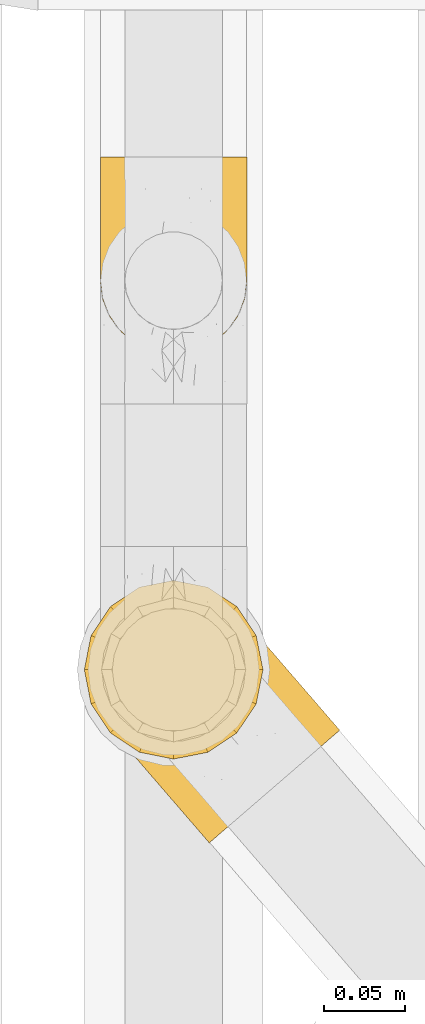
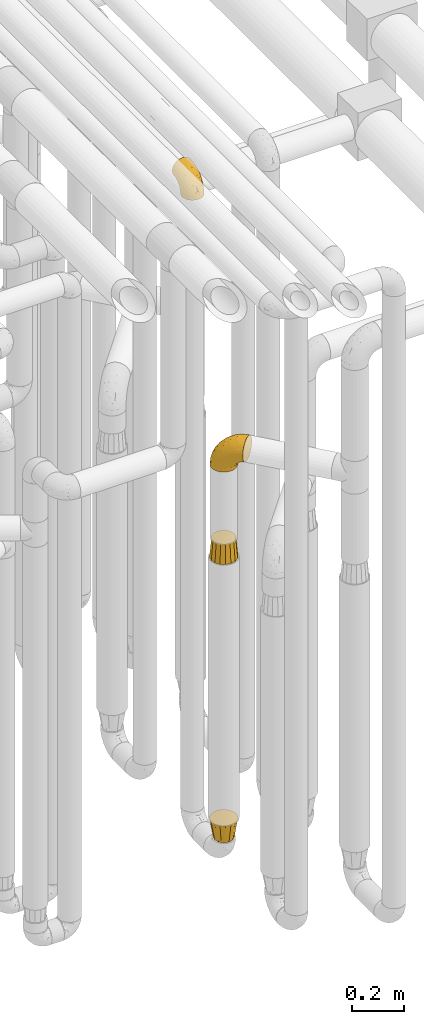
# One storey, part 203 of 827: 4 coverings.
"""IFC2X3 building model written with IfcOpenShell, lengths in millimetres."""

from ifc_helpers import new_model, entity, si_unit, converted_unit, derived_unit, direction, frame, origin, place, context, subcontext, project, spatial, faceted_brep, element, save


model = new_model("IFC2X3")

# Units and contexts
model_context = context("Model", 3, precision=0.01, world=origin(), true_north=direction((6.12303176911189e-17, 1.0)))
body_context = subcontext(model_context, "Body", "Model", "MODEL_VIEW")
ifc_project = project(units=[si_unit("LENGTHUNIT", "METRE", prefix="MILLI"), si_unit("AREAUNIT", "SQUARE_METRE"), si_unit("VOLUMEUNIT", "CUBIC_METRE"), converted_unit("PLANEANGLEUNIT", "DEGREE", entity("IfcRatioMeasure", 0.0174532925199433), si_unit("PLANEANGLEUNIT", "RADIAN"), dimensions=[0, 0, 0, 0, 0, 0, 0]), si_unit("MASSUNIT", "GRAM", prefix="KILO"), derived_unit("MASSDENSITYUNIT", [(si_unit("MASSUNIT", "GRAM", prefix="KILO"), 1), (si_unit("LENGTHUNIT", "METRE"), -3)]), derived_unit("MOMENTOFINERTIAUNIT", [(si_unit("LENGTHUNIT", "METRE"), 4)]), si_unit("TIMEUNIT", "SECOND"), si_unit("FREQUENCYUNIT", "HERTZ"), si_unit("THERMODYNAMICTEMPERATUREUNIT", "DEGREE_CELSIUS"), derived_unit("THERMALTRANSMITTANCEUNIT", [(si_unit("MASSUNIT", "GRAM", prefix="KILO"), 1), (si_unit("THERMODYNAMICTEMPERATUREUNIT", "KELVIN"), -1), (si_unit("TIMEUNIT", "SECOND"), -3)]), derived_unit("VOLUMETRICFLOWRATEUNIT", [(si_unit("LENGTHUNIT", "METRE"), 3), (si_unit("TIMEUNIT", "SECOND"), -1)]), derived_unit("MASSFLOWRATEUNIT", [(si_unit("MASSUNIT", "GRAM", prefix="KILO"), 1), (si_unit("TIMEUNIT", "SECOND"), -1)]), derived_unit("ROTATIONALFREQUENCYUNIT", [(si_unit("TIMEUNIT", "SECOND"), -1)]), si_unit("ELECTRICCURRENTUNIT", "AMPERE"), si_unit("ELECTRICVOLTAGEUNIT", "VOLT"), si_unit("POWERUNIT", "WATT"), si_unit("FORCEUNIT", "NEWTON", prefix="KILO"), si_unit("ILLUMINANCEUNIT", "LUX"), si_unit("LUMINOUSFLUXUNIT", "LUMEN"), si_unit("LUMINOUSINTENSITYUNIT", "CANDELA"), derived_unit("USERDEFINED", [(si_unit("MASSUNIT", "GRAM", prefix="KILO"), -1), (si_unit("LENGTHUNIT", "METRE"), -2), (si_unit("TIMEUNIT", "SECOND"), 3), (si_unit("LUMINOUSFLUXUNIT", "LUMEN"), 1)]), derived_unit("LINEARVELOCITYUNIT", [(si_unit("LENGTHUNIT", "METRE"), 1), (si_unit("TIMEUNIT", "SECOND"), -1)]), si_unit("PRESSUREUNIT", "PASCAL"), derived_unit("USERDEFINED", [(si_unit("LENGTHUNIT", "METRE"), -2), (si_unit("MASSUNIT", "GRAM", prefix="KILO"), 1), (si_unit("TIMEUNIT", "SECOND"), -2)]), derived_unit("LINEARFORCEUNIT", [(si_unit("MASSUNIT", "GRAM", prefix="KILO"), 1), (si_unit("LENGTHUNIT", "METRE"), 1), (si_unit("TIMEUNIT", "SECOND"), -2), (si_unit("LENGTHUNIT", "METRE"), -1)]), derived_unit("PLANARFORCEUNIT", [(si_unit("MASSUNIT", "GRAM", prefix="KILO"), 1), (si_unit("LENGTHUNIT", "METRE"), 1), (si_unit("TIMEUNIT", "SECOND"), -2), (si_unit("LENGTHUNIT", "METRE"), -2)])], contexts=[model_context])

# Site, building, storey
site_placement = place(None, origin())
site = spatial("IfcSite", under=ifc_project, at=site_placement, CompositionType="ELEMENT")
building_placement = place(site_placement, origin())
building = spatial("IfcBuilding", under=site, at=building_placement, CompositionType="ELEMENT")
storey_placement = place(building_placement, frame((0.0, 0.0, 28200.0)))
storey = spatial("IfcBuildingStorey", under=building, at=storey_placement, Name="08", CompositionType="ELEMENT", Elevation=28200.0)

# Coverings
covering_1_placement = place(storey_placement, frame((36575.14, 10372.03, 2208.4)))
element("IfcCovering", 1, at=covering_1_placement, inside=storey, Name=":ADSK_", ObjectType=":ADSK_", PredefinedType="INSULATION", context=body_context, shape_type="Brep", body=[
    faceted_brep([(125.52, 43.98, 148.32), (116.59, 36.27, 149.65), (107.66, 28.55, 148.31), (99.17, 21.22, 144.39), (91.55, 14.64, 138.06), (85.2, 9.15, 129.66), (80.42, 5.03, 119.6), (77.45, 2.46, 108.39), (76.44, 1.6, 96.6), (77.45, 2.47, 84.79), (80.42, 5.03, 73.57), (85.21, 9.16, 63.51), (91.57, 14.66, 55.11), (99.18, 21.23, 48.79), (107.67, 28.56, 44.87), (116.59, 36.27, 43.55), (125.53, 43.99, 44.88), (134.02, 51.32, 48.8), (141.63, 57.89, 55.13), (147.99, 63.38, 63.53), (152.77, 67.51, 73.59), (155.74, 70.07, 84.8), (156.75, 70.94, 96.6), (155.74, 70.07, 108.41), (152.77, 67.51, 119.62), (147.98, 63.37, 129.68), (141.62, 57.88, 138.08), (134.01, 51.31, 144.4), (77.6, 60.41, 1.6), (64.46, 56.06, 1.6), (50.63, 55.26, 1.6), (37.07, 58.07, 1.6), (24.7, 64.29, 1.6), (14.35, 73.5, 1.6), (6.75, 85.07, 1.6), (2.4, 98.22, 1.6), (1.6, 112.04, 1.6), (4.4, 125.6, 1.6), (10.62, 137.98, 1.6), (19.83, 148.32, 1.6), (31.4, 155.93, 1.6), (44.55, 160.28, 1.6), (58.38, 161.08, 1.6), (71.94, 158.27, 1.6), (84.31, 152.05, 1.6), (94.65, 142.84, 1.6), (102.26, 131.27, 1.6), (106.61, 118.12, 1.6), (107.41, 104.3, 1.6), (104.61, 90.73, 1.6), (98.39, 78.36, 1.6), (89.18, 68.02, 1.6), (51.35, 159.08, 27.97), (39.18, 154.64, 37.09), (55.45, 151.65, 58.27), (29.11, 152.23, 27.13), (23.13, 144.5, 39.91), (103.88, 115.37, 109.11), (85.23, 131.82, 94.41), (83.2, 120.56, 110.94), (53.69, 134.69, 89.69), (32.79, 133.31, 75.62), (48.17, 115.5, 106.28), (88.29, 143.75, 60.12), (76.96, 152.95, 41.41), (79.95, 146.72, 63.22), (85.72, 149.73, 32.05), (96.08, 139.8, 52.13), (105.4, 103.03, 123.27), (95.19, 99.22, 129.32), (114.54, 79.42, 138.3), (45.82, 147.85, 62.95), (34.36, 146.02, 55.89), (65.46, 156.85, 37.4), (91.55, 65.27, 144.6), (105.35, 73.91, 142.66), (68.92, 112.37, 117.85), (83.78, 91.71, 134.01), (96.7, 129.82, 89.25), (139.67, 89.32, 103.34), (135.16, 89.67, 113.52), (106.51, 129.11, 57.43), (102.1, 134.22, 44.19), (97.69, 139.32, 30.95), (105.59, 127.69, 77.98), (125.53, 80.92, 132.66), (122.95, 94.37, 121.52), (67.61, 138.68, 86.93), (71.95, 147.11, 68.4), (120.25, 113.2, 78.45), (113.38, 121.16, 67.94), (148.22, 80.81, 94.53), (137.56, 93.16, 91.95), (123.03, 108.59, 93.36), (128.9, 103.18, 85.2), (115.3, 112.48, 101.45), (68.21, 92.29, 129.81), (96.17, 141.08, 16.27), (118.48, 68.28, 42.46), (117.39, 80.68, 40.4), (124.87, 82.47, 49.71), (107.56, 125.69, 39.4), (109.79, 117.53, 31.26), (104.7, 128.74, 27.7), (101.82, 132.81, 16.7), (129.35, 99.09, 70.67), (137.5, 91.76, 81.69), (107.25, 118.91, 16.68), (92.85, 63.76, 22.57), (91.39, 65.45, 14.26), (100.01, 75.47, 17.68), (109.23, 100.97, 19.58), (113.57, 100.48, 33.49), (113.23, 89.81, 33.01), (113.14, 57.4, 40.69), (108.32, 45.85, 40.15), (102.89, 52.14, 37.93), (106.11, 70.25, 31.04), (116.74, 106.75, 45.29), (107.53, 85.3, 23.55), (103.59, 85.72, 11.36), (117.8, 113.29, 59.1), (124.29, 99.09, 57.42), (122.27, 109.37, 68.96), (109.18, 110.81, 20.38), (140.85, 82.29, 72.46), (146.48, 80.83, 83.66), (132.44, 84.4, 60.66), (139.38, 71.66, 61.01), (130.26, 69.79, 51.85), (124.47, 57.4, 46.07), (97.87, 57.95, 30.25), (112.36, 118.65, 46.65), (118.78, 92.23, 43.0), (53.66, 52.98, 19.58), (67.54, 18.98, 72.44), (80.23, 58.39, 17.67), (39.95, 43.86, 78.45), (43.44, 41.3, 68.97), (52.58, 32.81, 70.65), (96.2, 42.77, 40.69), (84.68, 39.07, 42.45), (84.52, 51.59, 31.04), (60.94, 42.26, 42.99), (46.79, 46.46, 45.18), (53.57, 48.61, 33.46), (66.68, 27.61, 60.64), (53.33, 37.82, 57.37), (26.21, 59.76, 57.43), (21.8, 64.87, 44.19), (29.45, 58.23, 39.35), (15.87, 71.74, 16.27), (23.23, 64.95, 16.7), (57.26, 23.81, 91.95), (48.6, 33.84, 85.2), (58.62, 23.7, 81.68), (35.65, 52.49, 46.68), (37.2, 54.84, 31.26), (36.2, 57.54, 16.68), (26.84, 61.5, 27.7), (78.28, 18.89, 60.99), (81.46, 27.64, 51.84), (72.56, 41.94, 40.41), (69.68, 34.8, 49.72), (94.56, 31.56, 46.06), (67.92, 11.47, 94.53), (69.57, 56.33, 11.35), (64.16, 47.39, 33.02), (68.16, 13.2, 83.65), (43.93, 54.46, 20.38), (33.08, 51.81, 67.94), (40.2, 46.3, 59.12), (69.4, 52.38, 23.53), (17.39, 69.98, 30.95), (11.35, 113.57, 58.27), (4.6, 118.71, 27.97), (4.75, 104.42, 37.4), (6.93, 92.48, 41.41), (14.62, 139.7, 27.21), (10.76, 130.1, 37.09), (19.3, 134.39, 53.2), (17.15, 71.64, 52.13), (60.74, 21.17, 103.34), (61.06, 25.67, 113.5), (41.39, 48.65, 101.45), (26.63, 81.21, 94.41), (40.18, 60.34, 109.08), (38.07, 81.55, 110.95), (44.1, 40.43, 93.36), (27.75, 60.47, 77.98), (8.84, 83.34, 32.05), (17.31, 122.48, 64.63), (52.16, 57.06, 123.25), (71.11, 33.91, 132.65), (57.44, 66.58, 129.32), (79.2, 38.73, 139.96), (48.25, 94.52, 117.85), (28.38, 112.84, 89.69), (58.2, 38.41, 121.51), (12.66, 88.61, 63.23), (26.89, 69.61, 89.17), (80.98, 52.86, 142.66), (13.44, 96.59, 68.4), (22.41, 99.65, 86.94), (14.38, 79.93, 60.12), (64.39, 75.17, 133.2)], [[[0, 1, 2, 3, 4, 5, 6, 7, 8, 9, 10, 11, 12, 13, 14, 15, 16, 17, 18, 19, 20, 21, 22, 23, 24, 25, 26, 27]], [[28, 29, 30, 31, 32, 33, 34, 35, 36, 37, 38, 39, 40, 41, 42, 43, 44, 45, 46, 47, 48, 49, 50, 51]], [[52, 53, 54]], [[55, 39, 56]], [[57, 58, 59]], [[60, 61, 62]], [[63, 64, 65]], [[66, 63, 67]], [[68, 69, 70]], [[53, 71, 54]], [[41, 40, 53]], [[53, 72, 71]], [[73, 42, 52]], [[42, 41, 52]], [[74, 0, 75]], [[69, 76, 77]], [[43, 73, 64]], [[45, 44, 66]], [[57, 78, 58]], [[23, 79, 80]], [[67, 81, 82, 83]], [[67, 84, 81]], [[24, 23, 80]], [[25, 85, 26]], [[86, 85, 25]], [[42, 73, 43]], [[0, 27, 75]], [[25, 24, 86]], [[70, 26, 85]], [[0, 74, 1]], [[68, 85, 86]], [[66, 64, 63]], [[60, 59, 87]], [[54, 87, 88]], [[76, 60, 62]], [[84, 89, 90, 81]], [[79, 22, 91, 92]], [[77, 74, 75]], [[93, 92, 94, 89]], [[80, 86, 24]], [[40, 55, 53]], [[76, 59, 60]], [[93, 84, 95]], [[76, 62, 96]], [[55, 72, 53]], [[70, 27, 26]], [[75, 70, 69]], [[78, 84, 63]], [[93, 79, 92]], [[95, 86, 80]], [[77, 76, 96]], [[59, 69, 68]], [[57, 68, 86]], [[68, 57, 59]], [[59, 58, 87]], [[76, 69, 59]], [[88, 87, 58]], [[87, 54, 71]], [[86, 95, 57]], [[78, 57, 95]], [[84, 78, 95]], [[78, 63, 65]], [[58, 78, 65]], [[54, 88, 73]], [[84, 93, 89]], [[79, 95, 80]], [[79, 93, 95]], [[22, 79, 23]], [[66, 83, 97, 45]], [[84, 67, 63]], [[83, 66, 67]], [[64, 44, 43]], [[64, 66, 44]], [[65, 73, 88]], [[53, 52, 41]], [[73, 52, 54]], [[73, 65, 64]], [[65, 88, 58]], [[39, 55, 40]], [[72, 55, 56]], [[56, 61, 72]], [[60, 72, 61]], [[72, 60, 71]], [[87, 71, 60]], [[27, 70, 75]], [[68, 70, 85]], [[74, 77, 96]], [[69, 77, 75]], [[98, 99, 100]], [[46, 45, 97]], [[101, 102, 103]], [[103, 104, 83]], [[105, 94, 106]], [[107, 103, 102]], [[108, 109, 51, 110]], [[111, 112, 113]], [[114, 115, 116]], [[47, 104, 107]], [[110, 117, 108]], [[49, 48, 111]], [[102, 118, 112]], [[119, 120, 111]], [[50, 49, 120]], [[121, 122, 118]], [[105, 123, 89]], [[124, 48, 107]], [[20, 19, 125]], [[121, 81, 90]], [[117, 119, 99]], [[21, 20, 126]], [[22, 21, 91]], [[105, 125, 127]], [[110, 51, 50]], [[19, 128, 125]], [[16, 15, 115]], [[129, 98, 100]], [[126, 91, 21]], [[128, 129, 127]], [[122, 123, 105]], [[114, 117, 98]], [[17, 16, 130]], [[18, 128, 19]], [[129, 18, 17]], [[125, 106, 126]], [[115, 114, 16]], [[130, 129, 17]], [[114, 98, 130]], [[117, 116, 131, 108]], [[99, 119, 113]], [[122, 121, 123]], [[92, 126, 106]], [[105, 127, 122]], [[132, 121, 118]], [[114, 130, 16]], [[129, 130, 98]], [[50, 120, 110]], [[129, 128, 18]], [[125, 128, 127]], [[125, 126, 20]], [[91, 126, 92]], [[105, 89, 94]], [[105, 106, 125]], [[94, 92, 106]], [[100, 122, 127]], [[118, 122, 133]], [[112, 118, 133]], [[132, 118, 102]], [[132, 102, 101]], [[81, 121, 132]], [[82, 103, 83]], [[132, 101, 81]], [[104, 47, 46]], [[124, 107, 102]], [[48, 47, 107]], [[113, 112, 133]], [[112, 111, 124]], [[99, 113, 133]], [[111, 113, 119]], [[99, 133, 100]], [[117, 99, 98]], [[122, 100, 133]], [[127, 129, 100]], [[103, 82, 101]], [[81, 101, 82]], [[112, 124, 102]], [[48, 124, 111]], [[104, 103, 107]], [[46, 97, 104]], [[111, 120, 49]], [[83, 104, 97]], [[110, 120, 119]], [[117, 110, 119]], [[116, 117, 114]], [[123, 90, 89]], [[90, 123, 121]], [[30, 29, 134]], [[11, 10, 135]], [[51, 109, 108, 136]], [[137, 138, 139]], [[140, 141, 142]], [[143, 144, 145]], [[146, 139, 147]], [[148, 149, 150]], [[151, 32, 152]], [[153, 154, 155]], [[156, 150, 157]], [[158, 157, 159]], [[108, 142, 136]], [[31, 158, 152]], [[160, 161, 12]], [[162, 163, 143]], [[140, 142, 116]], [[142, 141, 162]], [[14, 164, 140]], [[14, 140, 115]], [[9, 8, 165]], [[160, 12, 11]], [[141, 164, 161]], [[13, 12, 161]], [[14, 115, 15]], [[28, 166, 29]], [[135, 139, 146]], [[141, 163, 162]], [[135, 146, 160]], [[143, 167, 162]], [[29, 166, 134]], [[116, 142, 108, 131]], [[165, 153, 168]], [[10, 9, 168]], [[168, 135, 10]], [[138, 147, 139]], [[158, 169, 157]], [[14, 13, 164]], [[116, 115, 140]], [[145, 167, 143]], [[135, 160, 11]], [[168, 153, 155]], [[138, 170, 171]], [[157, 144, 156]], [[147, 144, 143]], [[161, 164, 13]], [[140, 164, 141]], [[142, 172, 136]], [[136, 172, 166]], [[161, 160, 146]], [[165, 168, 9]], [[155, 139, 135]], [[139, 154, 137]], [[168, 155, 135]], [[139, 155, 154]], [[144, 147, 171]], [[163, 147, 143]], [[156, 144, 171]], [[157, 169, 145]], [[171, 148, 156]], [[173, 159, 149]], [[159, 157, 150]], [[152, 159, 173]], [[159, 152, 158]], [[31, 30, 158]], [[169, 30, 134]], [[157, 145, 144]], [[167, 134, 172]], [[134, 167, 145]], [[172, 142, 162]], [[162, 167, 172]], [[163, 141, 161]], [[161, 146, 163]], [[147, 163, 146]], [[148, 150, 156]], [[149, 159, 150]], [[30, 169, 158]], [[145, 169, 134]], [[151, 33, 32]], [[31, 152, 32]], [[152, 173, 151]], [[28, 51, 136]], [[134, 166, 172]], [[28, 136, 166]], [[147, 138, 171]], [[170, 138, 137]], [[170, 148, 171]], [[174, 175, 176]], [[35, 34, 177]], [[178, 179, 180]], [[181, 173, 149, 148]], [[182, 183, 184]], [[185, 186, 187]], [[188, 189, 137]], [[190, 33, 151, 173]], [[191, 179, 174]], [[34, 190, 177]], [[39, 38, 178]], [[192, 193, 194]], [[4, 3, 195]], [[175, 179, 37]], [[38, 37, 179]], [[35, 176, 36]], [[196, 62, 197]], [[181, 190, 173]], [[37, 36, 175]], [[183, 6, 198]], [[189, 148, 170, 137]], [[185, 199, 200]], [[3, 2, 201]], [[202, 185, 203]], [[8, 7, 182]], [[200, 184, 186]], [[183, 7, 6]], [[181, 189, 204]], [[200, 189, 184]], [[5, 198, 6]], [[187, 203, 185]], [[195, 3, 201]], [[205, 196, 194]], [[62, 61, 197]], [[186, 198, 192]], [[180, 179, 191]], [[2, 1, 74]], [[198, 193, 192]], [[193, 5, 4]], [[194, 193, 195]], [[2, 74, 201]], [[5, 193, 198]], [[205, 74, 96]], [[188, 137, 154, 153]], [[62, 196, 96]], [[56, 178, 180]], [[198, 184, 183]], [[184, 188, 182]], [[203, 197, 191]], [[205, 194, 201]], [[187, 192, 194]], [[192, 187, 186]], [[194, 196, 187]], [[197, 187, 196]], [[197, 203, 187]], [[202, 174, 176]], [[200, 186, 185]], [[184, 198, 186]], [[199, 185, 202]], [[189, 200, 204]], [[174, 202, 203]], [[176, 177, 199]], [[189, 181, 148]], [[190, 181, 204]], [[190, 204, 177]], [[190, 34, 33]], [[188, 153, 182]], [[189, 188, 184]], [[182, 153, 165, 8]], [[183, 182, 7]], [[199, 177, 204]], [[35, 177, 176]], [[176, 175, 36]], [[179, 175, 174]], [[200, 199, 204]], [[176, 199, 202]], [[203, 191, 174]], [[180, 197, 61]], [[197, 180, 191]], [[61, 56, 180]], [[39, 178, 56]], [[38, 179, 178]], [[194, 195, 201]], [[4, 195, 193]], [[74, 205, 201]], [[96, 196, 205]]]),
])
covering_2_placement = place(storey_placement, frame((36582.9, 10672.98, 3322.4)))
element("IfcCovering", 2, at=covering_2_placement, inside=storey, Name=":ADSK_", ObjectType=":ADSK_", PredefinedType="INSULATION", context=body_context, shape_type="Brep", body=[
    faceted_brep([(2.73, 122.75, 87.65), (6.07, 122.75, 97.19), (11.45, 122.75, 105.75), (18.6, 122.75, 112.9), (27.16, 122.75, 118.28), (36.7, 122.75, 121.61), (46.75, 122.75, 122.75), (56.8, 122.75, 121.61), (66.34, 122.75, 118.27), (74.9, 122.75, 112.89), (82.05, 122.75, 105.74), (87.43, 122.75, 97.18), (90.76, 122.75, 87.64), (91.9, 122.75, 77.6), (90.76, 122.75, 67.54), (87.42, 122.75, 58.0), (82.04, 122.75, 49.44), (74.89, 122.75, 42.29), (66.33, 122.75, 36.91), (56.79, 122.75, 33.58), (46.75, 122.75, 32.45), (36.69, 122.75, 33.58), (27.15, 122.75, 36.92), (18.59, 122.75, 42.3), (11.44, 122.75, 49.45), (6.06, 122.75, 58.01), (2.73, 122.75, 67.55), (1.6, 122.75, 77.6), (58.43, 90.36, 1.6), (69.32, 85.85, 1.6), (78.67, 78.67, 1.6), (85.85, 69.32, 1.6), (90.36, 58.43, 1.6), (91.9, 46.75, 1.6), (90.36, 35.06, 1.6), (85.85, 24.17, 1.6), (78.67, 14.82, 1.6), (69.32, 7.64, 1.6), (58.43, 3.13, 1.6), (46.75, 1.6, 1.6), (35.06, 3.13, 1.6), (24.17, 7.64, 1.6), (14.82, 14.82, 1.6), (7.64, 24.17, 1.6), (3.13, 35.06, 1.6), (1.6, 46.75, 1.6), (3.13, 58.43, 1.6), (7.64, 69.32, 1.6), (14.82, 78.67, 1.6), (24.17, 85.85, 1.6), (35.06, 90.36, 1.6), (46.75, 91.9, 1.6), (46.75, 51.54, 99.61), (38.29, 47.17, 95.26), (46.75, 38.13, 86.21), (46.75, 7.52, 39.03), (38.96, 5.85, 30.75), (46.75, 5.11, 23.8), (33.86, 19.2, 60.8), (31.42, 38.98, 85.37), (21.63, 35.02, 73.64), (30.84, 8.21, 31.01), (22.16, 19.28, 49.14), (20.56, 12.19, 23.88), (2.29, 101.39, 82.74), (7.18, 34.43, 43.48), (12.6, 20.95, 29.47), (14.0, 30.74, 56.38), (2.81, 72.93, 72.18), (6.65, 56.64, 72.24), (6.11, 80.81, 87.6), (16.62, 93.43, 107.24), (9.76, 100.76, 101.1), (12.46, 74.27, 95.16), (1.6, 93.66, 71.81), (1.6, 81.33, 63.57), (1.6, 69.01, 55.34), (2.46, 40.87, 23.66), (5.91, 29.38, 20.55), (36.97, 67.05, 107.97), (46.75, 85.31, 116.82), (33.09, 93.68, 117.03), (1.6, 52.53, 30.68), (1.6, 50.71, 21.51), (1.6, 48.88, 12.33), (25.62, 72.77, 106.17), (3.14, 51.21, 52.37), (23.92, 101.18, 114.51), (46.75, 100.54, 119.23), (13.58, 48.74, 78.37), (1.6, 112.01, 75.46), (1.6, 102.83, 73.63), (18.5, 73.88, 101.51), (46.75, 24.73, 72.81), (1.6, 60.77, 43.01), (4.96, 103.08, 92.6), (20.84, 54.8, 91.86), (46.75, 16.13, 55.92), (30.52, 55.92, 99.01), (46.75, 68.42, 108.21), (27.29, 104.98, 32.05), (36.89, 108.58, 30.22), (33.6, 98.21, 23.37), (2.54, 61.56, 28.43), (3.27, 60.69, 16.44), (16.85, 100.0, 37.1), (21.91, 95.88, 28.88), (13.5, 90.81, 33.93), (3.96, 84.88, 50.17), (3.52, 73.29, 40.57), (12.17, 113.4, 47.62), (18.93, 109.8, 39.9), (9.34, 102.13, 47.92), (3.12, 67.29, 34.27), (5.67, 70.34, 24.65), (2.51, 95.15, 62.6), (2.53, 105.49, 66.18), (8.35, 71.5, 11.74), (35.39, 92.87, 13.89), (46.75, 96.03, 17.02), (15.1, 81.34, 15.86), (5.27, 107.44, 57.71), (27.43, 88.36, 9.11), (24.89, 90.43, 18.55), (29.71, 114.37, 34.74), (5.07, 98.41, 54.95), (2.88, 88.73, 57.35), (9.69, 76.89, 22.03), (15.51, 86.08, 24.8), (2.27, 112.64, 69.07), (10.03, 94.21, 42.31), (46.75, 112.22, 29.63), (46.75, 107.32, 28.31), (8.83, 79.95, 30.23), (7.16, 84.51, 40.13), (46.75, 101.67, 22.67), (46.75, 94.71, 12.12), (78.39, 81.34, 15.86), (83.8, 76.89, 22.03), (77.97, 86.08, 24.8), (84.66, 79.96, 30.23), (58.1, 92.87, 13.88), (81.31, 113.41, 47.61), (91.9, 102.83, 73.63), (90.96, 105.5, 66.17), (91.22, 112.64, 69.07), (56.59, 108.58, 30.22), (66.18, 104.98, 32.04), (59.87, 98.2, 23.36), (88.42, 98.4, 54.93), (84.13, 102.13, 47.91), (88.22, 107.44, 57.69), (66.06, 88.36, 9.1), (91.9, 50.71, 21.51), (91.9, 48.88, 12.33), (83.44, 94.22, 42.29), (76.62, 100.01, 37.09), (85.14, 71.5, 11.74), (90.22, 60.69, 16.44), (91.9, 52.53, 30.68), (71.55, 95.89, 28.86), (63.77, 114.37, 34.74), (91.9, 81.33, 63.57), (91.9, 69.01, 55.34), (89.53, 84.88, 50.17), (91.9, 112.01, 75.46), (74.55, 109.8, 39.89), (90.95, 61.56, 28.43), (90.37, 67.29, 34.27), (91.9, 60.77, 43.01), (90.98, 95.14, 62.59), (89.97, 73.29, 40.57), (86.32, 84.53, 40.13), (91.9, 93.66, 71.81), (79.97, 90.82, 33.92), (90.61, 88.73, 57.34), (87.82, 70.34, 24.65), (68.6, 90.43, 18.54), (80.89, 20.95, 29.47), (86.31, 34.43, 43.48), (79.49, 30.74, 56.4), (71.33, 19.29, 49.17), (71.88, 35.07, 73.69), (90.35, 51.21, 52.37), (86.85, 56.67, 72.26), (72.67, 54.85, 91.88), (62.08, 38.98, 85.36), (87.58, 29.38, 20.55), (91.03, 40.87, 23.66), (59.62, 19.2, 60.8), (62.65, 8.21, 31.02), (54.53, 5.85, 30.75), (72.93, 12.19, 23.9), (90.68, 72.93, 72.17), (87.39, 80.83, 87.59), (91.2, 101.39, 82.74), (60.41, 93.69, 117.03), (76.88, 93.43, 107.23), (56.53, 67.04, 107.97), (83.74, 100.76, 101.08), (67.88, 72.78, 106.17), (62.99, 55.93, 99.01), (69.58, 101.18, 114.5), (81.04, 74.27, 95.15), (75.0, 73.89, 101.5), (88.53, 103.09, 92.59), (79.93, 48.78, 78.38), (55.21, 47.19, 95.27)], [[[0, 1, 2, 3, 4, 5, 6, 7, 8, 9, 10, 11, 12, 13, 14, 15, 16, 17, 18, 19, 20, 21, 22, 23, 24, 25, 26, 27]], [[28, 29, 30, 31, 32, 33, 34, 35, 36, 37, 38, 39, 40, 41, 42, 43, 44, 45, 46, 47, 48, 49, 50, 51]], [[52, 53, 54]], [[55, 56, 57]], [[58, 59, 60]], [[61, 62, 63]], [[27, 64, 0]], [[65, 66, 67]], [[41, 40, 61]], [[68, 69, 70]], [[66, 43, 42]], [[63, 42, 41]], [[71, 72, 73]], [[72, 2, 1]], [[68, 74, 75, 76]], [[45, 44, 77]], [[43, 78, 44]], [[79, 80, 81]], [[77, 82, 83, 84, 45]], [[79, 81, 85]], [[71, 2, 72]], [[65, 86, 77]], [[4, 81, 5]], [[66, 65, 78]], [[4, 3, 87]], [[81, 88, 5]], [[63, 66, 42]], [[68, 70, 64]], [[67, 60, 89]], [[71, 3, 2]], [[64, 27, 90, 91, 74]], [[92, 71, 73]], [[40, 57, 56]], [[59, 93, 54]], [[86, 76, 94, 82]], [[1, 0, 95]], [[58, 62, 61]], [[60, 96, 89]], [[85, 81, 87]], [[56, 97, 58]], [[65, 67, 69]], [[87, 81, 4]], [[67, 89, 69]], [[61, 63, 41]], [[95, 72, 1]], [[73, 72, 70]], [[69, 73, 70]], [[73, 89, 96]], [[3, 71, 87]], [[85, 87, 71]], [[58, 61, 56]], [[59, 58, 93]], [[76, 86, 68]], [[69, 89, 73]], [[68, 86, 69]], [[65, 69, 86]], [[68, 64, 74]], [[95, 64, 70]], [[98, 79, 85]], [[79, 52, 99, 80]], [[66, 62, 67]], [[62, 58, 60]], [[62, 60, 67]], [[59, 98, 96]], [[59, 96, 60]], [[96, 85, 92]], [[88, 81, 80]], [[88, 6, 5]], [[66, 63, 62]], [[64, 95, 0]], [[72, 95, 70]], [[77, 44, 78]], [[86, 82, 77]], [[40, 39, 57]], [[96, 98, 85]], [[40, 56, 61]], [[66, 78, 43]], [[77, 78, 65]], [[79, 98, 53]], [[96, 92, 73]], [[85, 71, 92]], [[97, 56, 55]], [[97, 93, 58]], [[53, 98, 59]], [[54, 53, 59]], [[79, 53, 52]], [[100, 101, 102]], [[46, 45, 84, 83]], [[103, 104, 82]], [[82, 104, 83]], [[105, 106, 107]], [[108, 109, 76]], [[110, 111, 112]], [[103, 113, 114]], [[115, 74, 116]], [[48, 47, 117]], [[118, 102, 119]], [[49, 48, 120]], [[74, 91, 116]], [[116, 121, 115]], [[49, 122, 50]], [[123, 106, 102]], [[124, 111, 22]], [[125, 126, 115]], [[23, 22, 111]], [[24, 110, 121]], [[120, 127, 128]], [[90, 26, 129]], [[27, 26, 90]], [[121, 125, 115]], [[24, 121, 25]], [[130, 105, 107]], [[129, 25, 116]], [[21, 20, 131]], [[120, 123, 122]], [[112, 105, 130]], [[50, 118, 51]], [[21, 124, 22]], [[101, 131, 132]], [[117, 120, 48]], [[24, 23, 110]], [[127, 114, 133]], [[75, 108, 76]], [[107, 134, 130]], [[133, 114, 113]], [[129, 116, 91]], [[25, 121, 116]], [[121, 112, 125]], [[75, 74, 115]], [[101, 135, 102]], [[131, 101, 21]], [[101, 100, 124]], [[128, 127, 133]], [[119, 136, 51, 118]], [[104, 47, 46]], [[83, 104, 46]], [[117, 104, 114]], [[101, 124, 21]], [[111, 124, 100]], [[102, 118, 123]], [[133, 134, 107]], [[111, 110, 23]], [[114, 104, 103]], [[94, 76, 109]], [[121, 110, 112]], [[122, 118, 50]], [[134, 109, 108]], [[133, 107, 128]], [[112, 108, 125]], [[126, 125, 108]], [[108, 75, 126]], [[75, 115, 126]], [[109, 134, 133]], [[130, 108, 112]], [[108, 130, 134]], [[105, 112, 111]], [[111, 100, 105]], [[106, 105, 100]], [[102, 106, 100]], [[128, 106, 123]], [[90, 129, 91]], [[25, 129, 26]], [[104, 117, 47]], [[117, 114, 127]], [[82, 94, 103]], [[113, 94, 109]], [[94, 113, 103]], [[133, 113, 109]], [[106, 128, 107]], [[123, 120, 128]], [[120, 122, 49]], [[118, 122, 123]], [[135, 101, 132]], [[135, 119, 102]], [[117, 127, 120]], [[30, 29, 137]], [[138, 139, 140]], [[51, 136, 119, 141]], [[142, 17, 16]], [[143, 144, 145]], [[146, 147, 148]], [[149, 150, 151]], [[152, 29, 28]], [[33, 32, 153, 154]], [[150, 155, 156]], [[157, 31, 30]], [[153, 158, 159]], [[29, 152, 137]], [[148, 141, 119]], [[156, 160, 147]], [[148, 135, 146]], [[137, 138, 157]], [[19, 161, 146]], [[162, 163, 164]], [[14, 13, 165]], [[153, 32, 158]], [[147, 161, 166]], [[18, 17, 166]], [[167, 168, 169]], [[166, 150, 156]], [[151, 150, 142]], [[151, 170, 149]], [[151, 16, 15]], [[171, 140, 172]], [[165, 143, 145]], [[173, 170, 144]], [[142, 166, 17]], [[19, 131, 20]], [[144, 170, 151]], [[18, 161, 19]], [[173, 144, 143]], [[140, 139, 174]], [[171, 164, 163]], [[164, 172, 155]], [[151, 15, 144]], [[145, 15, 14]], [[173, 162, 170]], [[149, 175, 164]], [[19, 146, 131]], [[132, 131, 146]], [[160, 148, 147]], [[159, 158, 167]], [[135, 132, 146]], [[158, 32, 31]], [[157, 158, 31]], [[167, 158, 176]], [[166, 161, 18]], [[146, 161, 147]], [[148, 177, 141]], [[171, 168, 140]], [[171, 163, 169]], [[151, 142, 16]], [[166, 142, 150]], [[152, 141, 177]], [[51, 141, 28]], [[138, 140, 176]], [[172, 140, 174]], [[175, 149, 170]], [[164, 150, 149]], [[170, 162, 175]], [[162, 164, 175]], [[155, 172, 174]], [[171, 172, 164]], [[155, 174, 156]], [[164, 155, 150]], [[160, 156, 174]], [[147, 166, 156]], [[139, 160, 174]], [[148, 160, 177]], [[15, 145, 144]], [[165, 145, 14]], [[137, 157, 30]], [[158, 157, 176]], [[168, 167, 176]], [[169, 159, 167]], [[140, 168, 176]], [[169, 168, 171]], [[137, 177, 139]], [[160, 139, 177]], [[141, 152, 28]], [[137, 152, 177]], [[148, 119, 135]], [[157, 138, 176]], [[139, 138, 137]], [[178, 179, 180]], [[181, 180, 182]], [[179, 183, 184]], [[185, 186, 182]], [[187, 188, 179]], [[188, 33, 154, 153, 159]], [[181, 189, 190]], [[35, 34, 187]], [[191, 38, 190]], [[192, 178, 181]], [[179, 184, 180]], [[192, 190, 37]], [[37, 190, 38]], [[36, 35, 178]], [[54, 93, 186]], [[35, 187, 178]], [[193, 194, 184]], [[195, 173, 143, 165, 13]], [[195, 193, 173]], [[193, 163, 162, 173]], [[13, 12, 195]], [[8, 7, 196]], [[9, 197, 10]], [[198, 80, 99, 52]], [[196, 7, 88]], [[197, 199, 10]], [[182, 189, 181]], [[200, 198, 201]], [[200, 196, 198]], [[9, 8, 202]], [[194, 199, 203]], [[192, 37, 36]], [[80, 196, 88]], [[183, 159, 169, 163]], [[188, 34, 33]], [[202, 200, 197]], [[185, 203, 204]], [[202, 8, 196]], [[10, 199, 11]], [[12, 11, 205]], [[38, 191, 57]], [[189, 97, 191]], [[203, 199, 197]], [[205, 199, 194]], [[204, 203, 197]], [[184, 203, 206]], [[200, 202, 196]], [[197, 9, 202]], [[207, 54, 186]], [[97, 55, 191]], [[194, 203, 184]], [[183, 163, 193]], [[184, 206, 180]], [[183, 193, 184]], [[205, 195, 12]], [[193, 195, 194]], [[80, 198, 196]], [[207, 186, 201]], [[182, 180, 206]], [[181, 178, 180]], [[185, 182, 206]], [[182, 186, 189]], [[203, 185, 206]], [[185, 200, 201]], [[7, 6, 88]], [[178, 192, 36]], [[190, 192, 181]], [[199, 205, 11]], [[195, 205, 194]], [[159, 183, 188]], [[179, 188, 183]], [[57, 191, 55]], [[57, 39, 38]], [[189, 191, 190]], [[188, 187, 34]], [[178, 187, 179]], [[186, 93, 189]], [[197, 200, 204]], [[185, 204, 200]], [[189, 93, 97]], [[207, 198, 52]], [[185, 201, 186]], [[198, 207, 201]], [[54, 207, 52]]]),
])
covering_3_placement = place(storey_placement, frame((36573.05, 10423.61, 1781.0)))
element("IfcCovering", 3, at=covering_3_placement, inside=storey, Name=":ADSK_", ObjectType=":ADSK_", PredefinedType="INSULATION", context=body_context, shape_type="Brep", body=[
    faceted_brep([(35.55, 107.41, 0.0), (43.51, 108.99, 0.0), (56.6, 111.6, 0.0), (69.69, 108.99, 0.0), (77.64, 107.41, 0.0), (86.56, 101.45, 0.0), (95.49, 95.49, 0.0), (101.45, 86.56, 0.0), (107.41, 77.64, 0.0), (108.99, 69.69, 0.0), (111.6, 56.6, 0.0), (108.99, 43.51, 0.0), (107.41, 35.55, 0.0), (101.45, 26.63, 0.0), (95.49, 17.7, 0.0), (86.56, 11.74, 0.0), (77.64, 5.78, 0.0), (69.69, 4.2, 0.0), (56.6, 1.6, 0.0), (43.51, 4.2, 0.0), (35.55, 5.78, 0.0), (26.63, 11.74, 0.0), (17.7, 17.7, 0.0), (11.74, 26.63, 0.0), (5.78, 35.55, 0.0), (4.2, 43.51, 0.0), (1.6, 56.6, 0.0), (4.2, 69.69, 0.0), (5.78, 77.64, 0.0), (11.74, 86.56, 0.0), (17.7, 95.49, 0.0), (26.63, 101.45, 0.0), (9.1, 56.6, 89.0), (10.9, 47.51, 89.0), (12.71, 38.42, 89.0), (17.86, 30.71, 89.0), (23.01, 23.01, 89.0), (30.71, 17.86, 89.0), (38.42, 12.71, 89.0), (47.51, 10.9, 89.0), (56.6, 9.1, 89.0), (65.68, 10.9, 89.0), (74.77, 12.71, 89.0), (82.48, 17.86, 89.0), (90.18, 23.01, 89.0), (95.33, 30.71, 89.0), (100.48, 38.42, 89.0), (102.29, 47.51, 89.0), (104.1, 56.6, 89.0), (102.29, 65.68, 89.0), (100.48, 74.77, 89.0), (95.33, 82.48, 89.0), (90.18, 90.18, 89.0), (82.48, 95.33, 89.0), (74.77, 100.48, 89.0), (65.68, 102.29, 89.0), (56.6, 104.1, 89.0), (47.51, 102.29, 89.0), (38.42, 100.48, 89.0), (30.71, 95.33, 89.0), (23.01, 90.18, 89.0), (17.86, 82.48, 89.0), (12.71, 74.77, 89.0), (10.9, 65.68, 89.0)], [[[0, 1, 2, 3, 4, 5, 6, 7, 8, 9, 10, 11, 12, 13, 14, 15, 16, 17, 18, 19, 20, 21, 22, 23, 24, 25, 26, 27, 28, 29, 30, 31]], [[32, 33, 34, 35, 36, 37, 38, 39, 40, 41, 42, 43, 44, 45, 46, 47, 48, 49, 50, 51, 52, 53, 54, 55, 56, 57, 58, 59, 60, 61, 62, 63]], [[46, 12, 11, 10, 48, 47]], [[44, 14, 13, 12, 46, 45]], [[42, 16, 15, 14, 44, 43]], [[41, 40, 18, 17, 16, 42]], [[38, 20, 19, 18, 40, 39]], [[36, 22, 21, 20, 38, 37]], [[34, 24, 23, 22, 36, 35]], [[33, 32, 26, 25, 24, 34]], [[62, 28, 27, 26, 32, 63]], [[60, 30, 29, 28, 62, 61]], [[58, 0, 31, 30, 60, 59]], [[57, 56, 2, 1, 0, 58]], [[54, 4, 3, 2, 56, 55]], [[52, 6, 5, 4, 54, 53]], [[50, 8, 7, 6, 52, 51]], [[49, 48, 10, 9, 8, 50]]]),
])
covering_4_placement = place(storey_placement, frame((36573.05, 10423.61, 476.0)))
element("IfcCovering", 4, at=covering_4_placement, inside=storey, Name=":ADSK_", ObjectType=":ADSK_", PredefinedType="INSULATION", context=body_context, shape_type="Brep", body=[
    faceted_brep([(17.7, 95.49, 89.0), (11.74, 86.56, 89.0), (5.78, 77.64, 89.0), (3.69, 67.12, 89.0), (1.6, 56.6, 89.0), (3.69, 46.07, 89.0), (5.78, 35.55, 89.0), (11.74, 26.63, 89.0), (17.7, 17.7, 89.0), (26.63, 11.74, 89.0), (35.55, 5.78, 89.0), (46.07, 3.69, 89.0), (56.6, 1.6, 89.0), (67.12, 3.69, 89.0), (77.64, 5.78, 89.0), (86.56, 11.74, 89.0), (95.49, 17.7, 89.0), (101.45, 26.63, 89.0), (107.41, 35.55, 89.0), (109.5, 46.07, 89.0), (111.6, 56.6, 89.0), (109.5, 67.12, 89.0), (107.41, 77.64, 89.0), (101.45, 86.56, 89.0), (95.49, 95.49, 89.0), (86.56, 101.45, 89.0), (77.64, 107.41, 89.0), (67.12, 109.5, 89.0), (56.6, 111.6, 89.0), (46.07, 109.5, 89.0), (35.55, 107.41, 89.0), (26.63, 101.45, 89.0), (91.24, 76.6, 0.0), (93.92, 66.6, 0.0), (96.6, 56.6, 0.0), (93.92, 46.6, 0.0), (91.24, 36.6, 0.0), (83.92, 29.27, 0.0), (76.6, 21.95, 0.0), (66.6, 19.27, 0.0), (56.6, 16.6, 0.0), (46.6, 19.27, 0.0), (36.6, 21.95, 0.0), (29.27, 29.27, 0.0), (21.95, 36.6, 0.0), (19.27, 46.6, 0.0), (16.6, 56.6, 0.0), (19.27, 66.6, 0.0), (21.95, 76.6, 0.0), (29.27, 83.92, 0.0), (36.6, 91.24, 0.0), (46.6, 93.92, 0.0), (56.6, 96.6, 0.0), (66.6, 93.92, 0.0), (76.6, 91.24, 0.0), (83.92, 83.92, 0.0)], [[[0, 1, 2, 3, 4, 5, 6, 7, 8, 9, 10, 11, 12, 13, 14, 15, 16, 17, 18, 19, 20, 21, 22, 23, 24, 25, 26, 27, 28, 29, 30, 31]], [[32, 33, 34, 35, 36, 37, 38, 39, 40, 41, 42, 43, 44, 45, 46, 47, 48, 49, 50, 51, 52, 53, 54, 55]], [[21, 20, 34]], [[54, 25, 55]], [[55, 23, 32]], [[34, 33, 21]], [[24, 55, 25]], [[54, 26, 25]], [[23, 55, 24]], [[52, 27, 53]], [[23, 22, 32]], [[33, 32, 22]], [[27, 52, 28]], [[26, 54, 53]], [[27, 26, 53]], [[33, 22, 21]], [[29, 28, 52]], [[48, 1, 49]], [[49, 31, 50]], [[52, 51, 29]], [[0, 49, 1]], [[48, 2, 1]], [[31, 49, 0]], [[46, 3, 47]], [[31, 30, 50]], [[51, 50, 30]], [[3, 46, 4]], [[2, 48, 47]], [[3, 2, 47]], [[51, 30, 29]], [[5, 4, 46]], [[42, 9, 43]], [[43, 7, 44]], [[46, 45, 5]], [[8, 43, 9]], [[42, 10, 9]], [[7, 43, 8]], [[40, 11, 41]], [[7, 6, 44]], [[45, 44, 6]], [[11, 40, 12]], [[10, 42, 41]], [[11, 10, 41]], [[45, 6, 5]], [[13, 12, 40]], [[36, 17, 37]], [[37, 15, 38]], [[40, 39, 13]], [[16, 37, 17]], [[36, 18, 17]], [[15, 37, 16]], [[34, 19, 35]], [[15, 14, 38]], [[39, 38, 14]], [[19, 34, 20]], [[18, 36, 35]], [[19, 18, 35]], [[39, 14, 13]]]),
])

save(model, "model.ifc")
